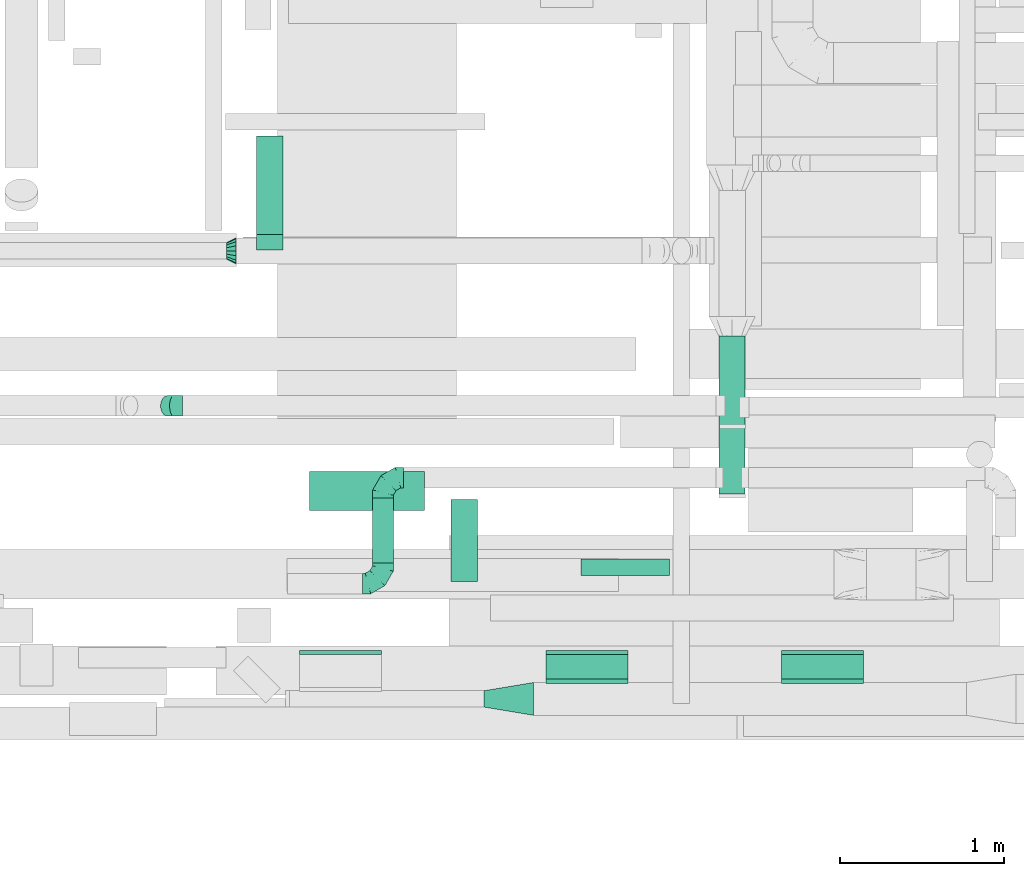
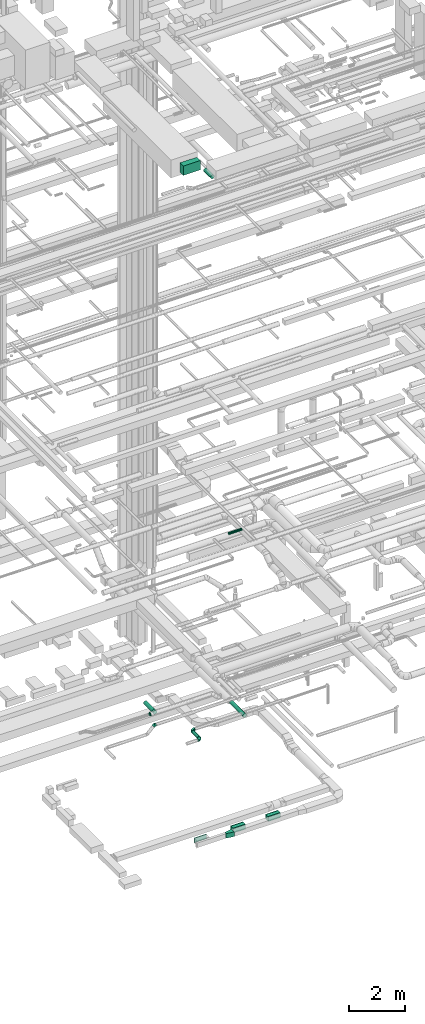
# One storey, part 116 of 337: 11 flow fittings, 8 flow segments.
"""IFC2X3 building model written with IfcOpenShell, lengths in millimetres."""

from ifc_helpers import new_model, entity, si_unit, converted_unit, derived_unit, direction, frame, origin, origin_2d_with_axis, place, context, subcontext, project, spatial, polyline, rectangle, circle, outline, extrude, faceted_brep, source, transform, mapped, material, type_object, type_shapes, element, save


model = new_model("IFC2X3")

# Units and contexts
model_context = context("Model", 3, precision=0.01, world=origin(), true_north=direction((6.12303176911189e-17, 1.0)))
body_context = subcontext(model_context, "Body", "Model", "MODEL_VIEW")
ifc_project = project(units=[si_unit("LENGTHUNIT", "METRE", prefix="MILLI"), si_unit("AREAUNIT", "SQUARE_METRE"), si_unit("VOLUMEUNIT", "CUBIC_METRE"), converted_unit("PLANEANGLEUNIT", "DEGREE", entity("IfcRatioMeasure", 0.0174532925199433), si_unit("PLANEANGLEUNIT", "RADIAN"), dimensions=[0, 0, 0, 0, 0, 0, 0]), si_unit("MASSUNIT", "GRAM", prefix="KILO"), derived_unit("MASSDENSITYUNIT", [(si_unit("MASSUNIT", "GRAM", prefix="KILO"), 1), (si_unit("LENGTHUNIT", "METRE"), -3)]), derived_unit("MOMENTOFINERTIAUNIT", [(si_unit("LENGTHUNIT", "METRE"), 4)]), si_unit("TIMEUNIT", "SECOND"), si_unit("FREQUENCYUNIT", "HERTZ"), si_unit("THERMODYNAMICTEMPERATUREUNIT", "DEGREE_CELSIUS"), derived_unit("THERMALTRANSMITTANCEUNIT", [(si_unit("MASSUNIT", "GRAM", prefix="KILO"), 1), (si_unit("THERMODYNAMICTEMPERATUREUNIT", "KELVIN"), -1), (si_unit("TIMEUNIT", "SECOND"), -3)]), derived_unit("VOLUMETRICFLOWRATEUNIT", [(si_unit("LENGTHUNIT", "METRE"), 3), (si_unit("TIMEUNIT", "SECOND"), -1)]), derived_unit("MASSFLOWRATEUNIT", [(si_unit("MASSUNIT", "GRAM", prefix="KILO"), 1), (si_unit("TIMEUNIT", "SECOND"), -1)]), derived_unit("ROTATIONALFREQUENCYUNIT", [(si_unit("TIMEUNIT", "SECOND"), -1)]), si_unit("ELECTRICCURRENTUNIT", "AMPERE"), si_unit("ELECTRICVOLTAGEUNIT", "VOLT"), si_unit("POWERUNIT", "WATT"), si_unit("FORCEUNIT", "NEWTON", prefix="KILO"), si_unit("ILLUMINANCEUNIT", "LUX"), si_unit("LUMINOUSFLUXUNIT", "LUMEN"), si_unit("LUMINOUSINTENSITYUNIT", "CANDELA"), derived_unit("USERDEFINED", [(si_unit("MASSUNIT", "GRAM", prefix="KILO"), -1), (si_unit("LENGTHUNIT", "METRE"), -2), (si_unit("TIMEUNIT", "SECOND"), 3), (si_unit("LUMINOUSFLUXUNIT", "LUMEN"), 1)]), derived_unit("LINEARVELOCITYUNIT", [(si_unit("LENGTHUNIT", "METRE"), 1), (si_unit("TIMEUNIT", "SECOND"), -1)]), si_unit("PRESSUREUNIT", "PASCAL"), derived_unit("USERDEFINED", [(si_unit("LENGTHUNIT", "METRE"), -2), (si_unit("MASSUNIT", "GRAM", prefix="KILO"), 1), (si_unit("TIMEUNIT", "SECOND"), -2)]), derived_unit("LINEARFORCEUNIT", [(si_unit("MASSUNIT", "GRAM", prefix="KILO"), 1), (si_unit("LENGTHUNIT", "METRE"), 1), (si_unit("TIMEUNIT", "SECOND"), -2), (si_unit("LENGTHUNIT", "METRE"), -1)]), derived_unit("PLANARFORCEUNIT", [(si_unit("MASSUNIT", "GRAM", prefix="KILO"), 1), (si_unit("LENGTHUNIT", "METRE"), 1), (si_unit("TIMEUNIT", "SECOND"), -2), (si_unit("LENGTHUNIT", "METRE"), -2)])], contexts=[model_context])

# Site, building, storey
site_placement = place(None, origin())
site = spatial("IfcSite", under=ifc_project, at=site_placement, CompositionType="ELEMENT")
building_placement = place(site_placement, origin())
building = spatial("IfcBuilding", under=site, at=building_placement, CompositionType="ELEMENT")
storey_placement = place(building_placement, origin())
storey = spatial("IfcBuildingStorey", under=building, at=storey_placement, CompositionType="ELEMENT", Elevation=0.0)

# Flow segments
duct_segment_type_1 = type_object("IfcDuctSegmentType", PredefinedType="NOTDEFINED")
flow_segment_1_placement = place(storey_placement, frame((28490.66, 768.22, -1000.0)))
element("IfcFlowSegment", 1, at=flow_segment_1_placement, inside=storey, type_object=duct_segment_type_1, context=body_context, shape_type="SweptSolid", body=[
    extrude(rectangle(XDim=149.999999999893, YDim=499.999999999999, at=origin_2d_with_axis()), frame((250.0, 75.0, 0.0), z_axis=(0.0, 0.0, 1.0), x_axis=(0.0, 1.0, 0.0)), (0.0, 0.0, 1.0), 200.0),
])
flow_segment_2_placement = place(storey_placement, frame((29923.65, 768.22, -1000.0)))
element("IfcFlowSegment", 2, at=flow_segment_2_placement, inside=storey, type_object=duct_segment_type_1, context=body_context, shape_type="SweptSolid", body=[
    extrude(rectangle(XDim=149.999999999862, YDim=499.999999999999, at=origin_2d_with_axis()), frame((250.0, 75.0, 0.0), z_axis=(0.0, 0.0, 1.0), x_axis=(0.0, 1.0, 0.0)), (0.0, 0.0, 1.0), 200.0),
])
flow_segment_3_placement = place(storey_placement, frame((27050.62, 1794.06, 27350.0)))
element("IfcFlowSegment", 3, at=flow_segment_3_placement, inside=storey, type_object=duct_segment_type_1, context=body_context, shape_type="SweptSolid", body=[
    extrude(rectangle(XDim=239.999999999895, YDim=700.000000000001, at=origin_2d_with_axis()), frame((350.0, 120.0, 0.0), z_axis=(0.0, 0.0, 1.0), x_axis=(0.0, 1.0, 0.0)), (0.0, 0.0, 1.0), 399.999999999996),
])
duct_segment_type_2 = type_object("IfcDuctSegmentType", PredefinedType="NOTDEFINED")
flow_segment_4_placement = place(storey_placement, frame((28703.43, 1398.72, 11418.4)))
element("IfcFlowSegment", 4, at=flow_segment_4_placement, inside=storey, type_object=duct_segment_type_2, context=body_context, shape_type="SweptSolid", body=[
    extrude(circle(Radius=50.0, at=origin_2d_with_axis()), frame((0.0, 51.6, 51.6), z_axis=(1.0, 0.0, 0.0), x_axis=(0.0, 1.0, 0.0)), (0.0, 0.0, 1.0), 540.000000000146),
])
flow_segment_5_placement = place(storey_placement, frame((29542.65, 1896.01, 2918.4)))
element("IfcFlowSegment", 5, at=flow_segment_5_placement, inside=storey, type_object=duct_segment_type_2, context=body_context, shape_type="SweptSolid", body=[
    extrude(circle(Radius=80.0, at=origin_2d_with_axis()), frame((81.6, 0.0, 81.6), z_axis=(0.0, 1.0, 0.0), x_axis=(-1.0, 0.0, 0.0)), (0.0, 0.0, 1.0), 960.0),
])
flow_segment_6_placement = place(storey_placement, frame((26728.31, 3475.7, 3138.4)))
element("IfcFlowSegment", 6, at=flow_segment_6_placement, inside=storey, type_object=duct_segment_type_2, context=body_context, shape_type="SweptSolid", body=[
    extrude(circle(Radius=80.0, at=origin_2d_with_axis()), frame((81.6, 0.0, 81.6), z_axis=(0.0, 1.0, 0.0), x_axis=(1.0, 0.0, 0.0)), (0.0, 0.0, 1.0), 599.999999999912),
])
flow_segment_7_placement = place(storey_placement, frame((27912.15, 1361.51, 27138.4)))
element("IfcFlowSegment", 7, at=flow_segment_7_placement, inside=storey, type_object=duct_segment_type_2, context=body_context, shape_type="SweptSolid", body=[
    extrude(circle(Radius=80.0, at=origin_2d_with_axis()), frame((81.6, 0.0, 81.6), z_axis=(0.0, 1.0, 0.0), x_axis=(1.0, 0.0, 0.0)), (0.0, 0.0, 1.0), 500.000000000006),
])
flow_segment_8_placement = place(storey_placement, frame((27434.93, 1475.7, 2985.9)))
element("IfcFlowSegment", 8, at=flow_segment_8_placement, inside=storey, type_object=duct_segment_type_2, context=body_context, shape_type="SweptSolid", body=[
    extrude(circle(Radius=62.5, at=origin_2d_with_axis()), frame((64.1, 0.0, 64.1), z_axis=(0.0, 1.0, 0.0), x_axis=(-1.0, 0.0, 0.0)), (0.0, 0.0, 1.0), 395.000000000017),
])

# Flow fittings
ifc_material = material()
duct_fitting_type_1 = type_object("IfcDuctFittingType", PredefinedType="NOTDEFINED", material=ifc_material)
shared_shape_1 = source(origin(), body_context, "Body", "SweptSolid", [
    extrude(outline(polyline([(-164.4, -73.98), (139.74, -73.98), (156.18, 24.66), (-131.52, 123.3), (-164.4, -73.98)])), frame((150.0, 0.0, -100.0), z_axis=(0.0, 0.0, 1.0), x_axis=(0.986393923832144, 0.164398987305356, 0.0)), (0.0, 0.0, 1.0), 200.0),
])
type_shapes(duct_fitting_type_1, [shared_shape_1])
flow_fitting_1_placement = place(storey_placement, frame((28414.6, 648.22, -900.0), z_axis=(0.0, 0.0, 1.0), x_axis=(-1.0, 0.0, 0.0)))
element("IfcFlowFitting", 9, at=flow_fitting_1_placement, inside=storey, type_object=duct_fitting_type_1, material=ifc_material, context=body_context, shape_type="MappedRepresentation", body=[
    mapped(shared_shape_1, transform((0.0, 0.0, 0.0), scale=1.0)),
])
duct_fitting_type_2 = type_object("IfcDuctFittingType", PredefinedType="NOTDEFINED", material=ifc_material)
shared_shape_2 = source(origin(), body_context, "Body", "SweptSolid", [
    extrude(rectangle(XDim=500.0, YDim=26.0960000002426, at=origin_2d_with_axis()), frame((6.95, 0.0, -100.0), z_axis=(0.0, 0.0, 1.0), x_axis=(0.0, -1.0, 0.0)), (0.0, 0.0, 1.0), 200.0),
])
type_shapes(duct_fitting_type_2, [shared_shape_2])
for number, where, z_axis, x_axis in (
    (10, (28740.66, 748.22, -900.0), (0.0, 0.0, -1.0), (0.0, 1.0, 0.0)),
    (11, (30173.65, 748.22, -900.0), (0.0, 0.0, -1.0), (0.0, 1.0, 0.0)),
):
    element("IfcFlowFitting", number, at=place(storey_placement, frame(where, z_axis=z_axis, x_axis=x_axis)), inside=storey, type_object=duct_fitting_type_2, material=ifc_material, context=body_context, shape_type="MappedRepresentation", body=[
        mapped(shared_shape_2, transform((0.0, 0.0, 0.0), scale=1.0)),
    ])
duct_fitting_type_3 = type_object("IfcDuctFittingType", PredefinedType="NOTDEFINED", material=ifc_material)
shared_shape_3 = source(origin(), body_context, "Body", "SweptSolid", [
    extrude(rectangle(XDim=24.9999999999999, YDim=500.0, at=origin_2d_with_axis()), frame((12.5, 0.0, -100.0)), (0.0, 0.0, 1.0), 200.0),
])
type_shapes(duct_fitting_type_3, [shared_shape_3])
for number, where, z_axis, x_axis in (
    (12, (30173.65, 918.22, -900.0), (0.0, 0.0, 1.0), (0.0, 1.0, 0.0)),
    (13, (28740.66, 918.22, -900.0), (0.0, 0.0, 1.0), (0.0, 1.0, 0.0)),
    (14, (27240.21, 918.22, -900.0), (0.0, 0.0, 1.0), (0.0, 1.0, 0.0)),
):
    element("IfcFlowFitting", number, at=place(storey_placement, frame(where, z_axis=z_axis, x_axis=x_axis)), inside=storey, type_object=duct_fitting_type_3, material=ifc_material, context=body_context, shape_type="MappedRepresentation", body=[
        mapped(shared_shape_3, transform((0.0, 0.0, 0.0), scale=1.0)),
    ])
duct_fitting_type_4 = type_object("IfcDuctFittingType", PredefinedType="NOTDEFINED", material=ifc_material)
shared_shape_4 = source(origin(), body_context, "Body", "Brep", [
    faceted_brep([(-125.0, 0.0, -62.5), (-125.0, -16.18, -60.37), (-125.0, -31.25, -54.13), (-125.0, -44.19, -44.19), (-125.0, -54.13, -31.25), (-125.0, -60.37, -16.18), (-125.0, -62.5, 0.0), (-125.0, -60.37, 16.18), (-125.0, -54.13, 31.25), (-125.0, -44.19, 44.19), (-125.0, -31.25, 54.13), (-125.0, -16.18, 60.37), (-125.0, 0.0, 62.5), (-125.0, 16.18, 60.37), (-125.0, 31.25, 54.13), (-125.0, 44.19, 44.19), (-125.0, 54.13, 31.25), (-125.0, 60.37, 16.18), (-125.0, 62.5, 0.0), (-125.0, 60.37, -16.18), (-125.0, 54.13, -31.25), (-125.0, 44.19, -44.19), (-125.0, 31.25, -54.13), (-125.0, 16.18, -60.37), (-95.84, 16.18, 60.37), (-99.88, 31.25, 54.13), (-91.51, 0.0, 62.5), (-103.35, 44.19, 44.19), (-107.68, 60.37, 16.18), (-108.25, 62.5, 0.0), (-106.01, 54.13, 31.25), (-106.01, 54.13, -31.25), (-103.35, 44.19, -44.19), (-107.68, 60.37, -16.18), (-95.84, 16.18, -60.37), (-91.51, 0.0, -62.5), (-99.88, 31.25, -54.13), (-87.17, -16.18, -60.37), (-83.13, -31.25, -54.13), (-79.66, -44.19, -44.19), (-77.0, -54.13, -31.25), (-75.33, -60.37, -16.18), (-74.76, -62.5, 0.0), (-75.33, -60.37, 16.18), (-77.0, -54.13, 31.25), (-79.66, -44.19, 44.19), (-83.13, -31.25, 54.13), (-87.17, -16.18, 60.37), (-45.34, 45.34, 60.37), (-56.37, 56.37, 54.13), (-33.49, 33.49, 62.5), (-65.85, 65.85, 44.19), (-73.12, 73.12, 31.25), (-77.69, 77.69, 16.18), (-79.25, 79.25, 0.0), (-77.69, 77.69, -16.18), (-73.12, 73.12, -31.25), (-65.85, 65.85, -44.19), (-45.34, 45.34, -60.37), (-33.49, 33.49, -62.5), (-56.37, 56.37, -54.13), (-21.65, 21.65, -60.37), (-10.62, 10.62, -54.13), (-1.14, 1.14, -44.19), (6.13, -6.13, -31.25), (10.7, -10.7, -16.18), (12.26, -12.26, 0.0), (10.7, -10.7, 16.18), (6.13, -6.13, 31.25), (-1.14, 1.14, 44.19), (-10.62, 10.62, 54.13), (-21.65, 21.65, 60.37), (-16.18, 95.84, 60.37), (-31.25, 99.88, 54.13), (0.0, 91.51, 62.5), (-44.19, 103.35, 44.19), (-54.13, 106.01, 31.25), (-60.37, 107.68, 16.18), (-62.5, 108.25, 0.0), (-60.37, 107.68, -16.18), (-54.13, 106.01, -31.25), (-44.19, 103.35, -44.19), (-16.18, 95.84, -60.37), (0.0, 91.51, -62.5), (-31.25, 99.88, -54.13), (16.18, 87.17, -60.37), (31.25, 83.13, -54.13), (44.19, 79.66, -44.19), (54.13, 77.0, -31.25), (60.37, 75.33, -16.18), (62.5, 74.76, 0.0), (60.37, 75.33, 16.18), (54.13, 77.0, 31.25), (44.19, 79.66, 44.19), (31.25, 83.13, 54.13), (16.18, 87.17, 60.37), (-16.18, 125.0, -60.37), (-31.25, 125.0, -54.13), (-44.19, 125.0, -44.19), (-54.13, 125.0, -31.25), (-60.37, 125.0, -16.18), (-62.5, 125.0, 0.0), (-60.37, 125.0, 16.18), (-54.13, 125.0, 31.25), (-44.19, 125.0, 44.19), (-31.25, 125.0, 54.13), (-16.18, 125.0, 60.37), (0.0, 125.0, 62.5), (16.18, 125.0, 60.37), (31.25, 125.0, 54.13), (44.19, 125.0, 44.19), (54.13, 125.0, 31.25), (60.37, 125.0, 16.18), (62.5, 125.0, 0.0), (60.37, 125.0, -16.18), (54.13, 125.0, -31.25), (44.19, 125.0, -44.19), (31.25, 125.0, -54.13), (16.18, 125.0, -60.37), (0.0, 125.0, -62.5)], [[[0, 1, 2, 3, 4, 5, 6, 7, 8, 9, 10, 11, 12, 13, 14, 15, 16, 17, 18, 19, 20, 21, 22, 23]], [[24, 25, 14, 13]], [[26, 24, 13, 12]], [[14, 25, 27, 15]], [[28, 29, 18, 17]], [[30, 28, 17, 16]], [[15, 27, 30, 16]], [[20, 31, 32, 21]], [[33, 31, 20, 19]], [[18, 29, 33, 19]], [[34, 35, 0, 23]], [[36, 34, 23, 22]], [[21, 32, 36, 22]], [[1, 0, 35, 37]], [[2, 1, 37, 38]], [[38, 39, 3, 2]], [[5, 4, 40, 41]], [[6, 5, 41, 42]], [[39, 40, 4, 3]], [[6, 42, 43, 7]], [[7, 43, 44, 8]], [[45, 9, 8, 44]], [[9, 45, 46, 10]], [[10, 46, 47, 11]], [[26, 12, 11, 47]], [[48, 49, 25, 24]], [[50, 48, 24, 26]], [[27, 25, 49, 51]], [[52, 53, 28, 30]], [[51, 52, 30, 27]], [[29, 28, 53, 54]], [[55, 56, 31, 33]], [[54, 55, 33, 29]], [[57, 32, 31, 56]], [[58, 59, 35, 34]], [[60, 58, 34, 36]], [[57, 60, 36, 32]], [[37, 35, 59, 61]], [[38, 37, 61, 62]], [[39, 38, 62, 63]], [[41, 40, 64, 65]], [[42, 41, 65, 66]], [[63, 64, 40, 39]], [[43, 42, 66, 67]], [[44, 43, 67, 68]], [[68, 69, 45, 44]], [[46, 45, 69, 70]], [[47, 46, 70, 71]], [[26, 47, 71, 50]], [[72, 73, 49, 48]], [[74, 72, 48, 50]], [[51, 49, 73, 75]], [[76, 77, 53, 52]], [[75, 76, 52, 51]], [[54, 53, 77, 78]], [[79, 80, 56, 55]], [[78, 79, 55, 54]], [[81, 57, 56, 80]], [[82, 83, 59, 58]], [[84, 82, 58, 60]], [[81, 84, 60, 57]], [[61, 59, 83, 85]], [[62, 61, 85, 86]], [[63, 62, 86, 87]], [[65, 64, 88, 89]], [[66, 65, 89, 90]], [[87, 88, 64, 63]], [[67, 66, 90, 91]], [[68, 67, 91, 92]], [[92, 93, 69, 68]], [[70, 69, 93, 94]], [[71, 70, 94, 95]], [[50, 71, 95, 74]], [[96, 97, 98, 99, 100, 101, 102, 103, 104, 105, 106, 107, 108, 109, 110, 111, 112, 113, 114, 115, 116, 117, 118, 119]], [[72, 74, 107, 106]], [[73, 72, 106, 105]], [[75, 73, 105, 104]], [[77, 76, 103, 102]], [[78, 77, 102, 101]], [[75, 104, 103, 76]], [[78, 101, 100, 79]], [[79, 100, 99, 80]], [[80, 99, 98, 81]], [[96, 119, 83, 82]], [[97, 96, 82, 84]], [[84, 81, 98, 97]], [[83, 119, 118, 85]], [[85, 118, 117, 86]], [[116, 87, 86, 117]], [[88, 115, 114, 89]], [[89, 114, 113, 90]], [[115, 88, 87, 116]], [[91, 90, 113, 112]], [[92, 91, 112, 111]], [[111, 110, 93, 92]], [[95, 94, 109, 108]], [[74, 95, 108, 107]], [[110, 109, 94, 93]]]),
])
type_shapes(duct_fitting_type_4, [shared_shape_4])
flow_fitting_2_placement = place(storey_placement, frame((27499.02, 1995.7, 3050.0), z_axis=(0.0, 0.0, 1.0), x_axis=(-1.0, 0.0, 0.0)))
element("IfcFlowFitting", 15, at=flow_fitting_2_placement, inside=storey, type_object=duct_fitting_type_4, material=ifc_material, context=body_context, shape_type="MappedRepresentation", body=[
    mapped(shared_shape_4, transform((0.0, 0.0, 0.0), scale=1.0)),
])
flow_fitting_3_placement = place(storey_placement, frame((27499.02, 1350.7, 3050.0)))
element("IfcFlowFitting", 16, at=flow_fitting_3_placement, inside=storey, type_object=duct_fitting_type_4, material=ifc_material, context=body_context, shape_type="MappedRepresentation", body=[
    mapped(shared_shape_4, transform((0.0, 0.0, 0.0), scale=1.0)),
])
duct_fitting_type_5 = type_object("IfcDuctFittingType", PredefinedType="NOTDEFINED", material=ifc_material)
shared_shape_5 = source(origin(), body_context, "Body", "Brep", [
    faceted_brep([(-51.78, 0.0, -62.5), (-51.78, -16.18, -60.37), (-51.78, -31.25, -54.13), (-51.78, -44.19, -44.19), (-51.78, -54.13, -31.25), (-51.78, -60.37, -16.18), (-51.78, -62.5, 0.0), (-51.78, -60.37, 16.18), (-51.78, -54.13, 31.25), (-51.78, -44.19, 44.19), (-51.78, -31.25, 54.13), (-51.78, -16.18, 60.37), (-51.78, 0.0, 62.5), (-51.78, 16.18, 60.37), (-51.78, 31.25, 54.13), (-51.78, 44.19, 44.19), (-51.78, 54.13, 31.25), (-51.78, 60.37, 16.18), (-51.78, 62.5, 0.0), (-51.78, 60.37, -16.18), (-51.78, 54.13, -31.25), (-51.78, 44.19, -44.19), (-51.78, 31.25, -54.13), (-51.78, 16.18, -60.37), (-6.7, 16.18, 60.37), (-12.94, 31.25, 54.13), (0.0, 0.0, 62.5), (-18.31, 44.19, 44.19), (-22.42, 54.13, 31.25), (-25.01, 60.37, 16.18), (-25.89, 62.5, 0.0), (-25.01, 60.37, -16.18), (-22.42, 54.13, -31.25), (-18.31, 44.19, -44.19), (-6.7, 16.18, -60.37), (0.0, 0.0, -62.5), (-12.94, 31.25, -54.13), (6.7, -16.18, -60.37), (12.94, -31.25, -54.13), (18.31, -44.19, -44.19), (22.42, -54.13, -31.25), (25.01, -60.37, -16.18), (25.89, -62.5, 0.0), (25.01, -60.37, 16.18), (22.42, -54.13, 31.25), (18.31, -44.19, 44.19), (12.94, -31.25, 54.13), (6.7, -16.18, 60.37), (25.17, 48.05, 60.37), (14.51, 58.71, 54.13), (36.61, 36.61, 62.5), (5.36, 67.86, 44.19), (-1.66, 74.88, 31.25), (-6.08, 79.3, 16.18), (-7.58, 80.81, 0.0), (-6.08, 79.3, -16.18), (-1.66, 74.88, -31.25), (5.36, 67.86, -44.19), (14.51, 58.71, -54.13), (25.17, 48.05, -60.37), (36.61, 36.61, -62.5), (48.05, 25.17, -60.37), (58.71, 14.51, -54.13), (67.86, 5.36, -44.19), (74.88, -1.66, -31.25), (79.3, -6.08, -16.18), (80.81, -7.58, 0.0), (79.3, -6.08, 16.18), (74.88, -1.66, 31.25), (67.86, 5.36, 44.19), (58.71, 14.51, 54.13), (48.05, 25.17, 60.37)], [[[0, 1, 2, 3, 4, 5, 6, 7, 8, 9, 10, 11, 12, 13, 14, 15, 16, 17, 18, 19, 20, 21, 22, 23]], [[24, 25, 14, 13]], [[26, 24, 13, 12]], [[27, 15, 14, 25]], [[28, 29, 17, 16]], [[28, 16, 15, 27]], [[30, 18, 17, 29]], [[31, 32, 20, 19]], [[30, 31, 19, 18]], [[21, 20, 32, 33]], [[34, 35, 0, 23]], [[36, 34, 23, 22]], [[33, 36, 22, 21]], [[1, 0, 35, 37]], [[2, 1, 37, 38]], [[38, 39, 3, 2]], [[5, 4, 40, 41]], [[6, 5, 41, 42]], [[39, 40, 4, 3]], [[6, 42, 43, 7]], [[7, 43, 44, 8]], [[8, 44, 45, 9]], [[9, 45, 46, 10]], [[10, 46, 47, 11]], [[26, 12, 11, 47]], [[48, 49, 25, 24]], [[50, 48, 24, 26]], [[27, 25, 49, 51]], [[29, 28, 52, 53]], [[30, 29, 53, 54]], [[51, 52, 28, 27]], [[30, 54, 55, 31]], [[31, 55, 56, 32]], [[57, 33, 32, 56]], [[36, 58, 59, 34]], [[34, 59, 60, 35]], [[58, 36, 33, 57]], [[35, 60, 61, 37]], [[37, 61, 62, 38]], [[63, 39, 38, 62]], [[40, 64, 65, 41]], [[41, 65, 66, 42]], [[64, 40, 39, 63]], [[43, 42, 66, 67]], [[44, 43, 67, 68]], [[68, 69, 45, 44]], [[47, 46, 70, 71]], [[26, 47, 71, 50]], [[69, 70, 46, 45]], [[59, 58, 57, 56, 55, 54, 53, 52, 51, 49, 48, 50, 71, 70, 69, 68, 67, 66, 65, 64, 63, 62, 61, 60]]]),
])
type_shapes(duct_fitting_type_5, [shared_shape_5])
flow_fitting_4_placement = place(storey_placement, frame((26225.76, 2432.13, 3450.0), z_axis=(0.0, -1.0, 0.0), x_axis=(-1.0, 0.0, 0.0)))
element("IfcFlowFitting", 17, at=flow_fitting_4_placement, inside=storey, type_object=duct_fitting_type_5, material=ifc_material, context=body_context, shape_type="MappedRepresentation", body=[
    mapped(shared_shape_5, transform((0.0, 0.0, 0.0), scale=1.0)),
])
duct_fitting_type_6 = type_object("IfcDuctFittingType", PredefinedType="NOTDEFINED", material=ifc_material)
shared_shape_6 = source(origin(), body_context, "Body", "Brep", [
    faceted_brep([(60.0, 0.0, -80.0), (60.0, 14.27, -77.16), (60.0, 30.61, -73.91), (60.0, 43.59, -65.24), (60.0, 56.57, -56.57), (60.0, 65.24, -43.59), (60.0, 73.91, -30.61), (60.0, 77.16, -14.27), (60.0, 80.0, 0.0), (60.0, 77.16, 14.27), (60.0, 73.91, 30.61), (60.0, 65.24, 43.59), (60.0, 56.57, 56.57), (60.0, 43.59, 65.24), (60.0, 30.61, 73.91), (60.0, 14.27, 77.16), (60.0, 0.0, 80.0), (60.0, -14.27, 77.16), (60.0, -30.61, 73.91), (60.0, -43.59, 65.24), (60.0, -56.57, 56.57), (60.0, -65.24, 43.59), (60.0, -73.91, 30.61), (60.0, -77.16, 14.27), (60.0, -80.0, 0.0), (60.0, -77.16, -14.27), (60.0, -73.91, -30.61), (60.0, -65.24, -43.59), (60.0, -56.57, -56.57), (60.0, -43.59, -65.24), (60.0, -30.61, -73.91), (60.0, -14.27, -77.16), (0.0, -19.13, -46.19), (0.0, -27.24, -40.77), (0.0, -35.36, -35.36), (0.0, -40.77, -27.24), (0.0, -46.19, -19.13), (0.0, -48.1, -9.57), (0.0, -50.0, 0.0), (0.0, -48.1, 9.57), (0.0, -46.19, 19.13), (0.0, -40.77, 27.24), (0.0, -35.36, 35.36), (0.0, -27.24, 40.77), (0.0, -19.13, 46.19), (0.0, -9.57, 48.1), (0.0, 0.0, 50.0), (0.0, 9.57, 48.1), (0.0, 19.13, 46.19), (0.0, 27.24, 40.77), (0.0, 35.36, 35.36), (0.0, 40.77, 27.24), (0.0, 46.19, 19.13), (0.0, 48.1, 9.57), (0.0, 50.0, 0.0), (0.0, 48.1, -9.57), (0.0, 46.19, -19.13), (0.0, 40.77, -27.24), (0.0, 35.36, -35.36), (0.0, 27.24, -40.77), (0.0, 19.13, -46.19), (0.0, 9.57, -48.1), (0.0, 0.0, -50.0), (0.0, -9.57, -48.1)], [[[0, 1, 2, 3, 4, 5, 6, 7, 8, 9, 10, 11, 12, 13, 14, 15, 16, 17, 18, 19, 20, 21, 22, 23, 24, 25, 26, 27, 28, 29, 30, 31]], [[32, 33, 34, 35, 36, 37, 38, 39, 40, 41, 42, 43, 44, 45, 46, 47, 48, 49, 50, 51, 52, 53, 54, 55, 56, 57, 58, 59, 60, 61, 62, 63]], [[52, 51, 50, 12, 11, 10]], [[48, 14, 13, 12, 50, 49]], [[10, 9, 8, 54, 53, 52]], [[15, 14, 48, 47, 46, 16]], [[44, 43, 42, 20, 19, 18]], [[40, 22, 21, 20, 42, 41]], [[18, 17, 16, 46, 45, 44]], [[23, 22, 40, 39, 38, 24]], [[36, 35, 34, 28, 27, 26]], [[32, 30, 29, 28, 34, 33]], [[26, 25, 24, 38, 37, 36]], [[31, 30, 32, 63, 62, 0]], [[60, 59, 58, 4, 3, 2]], [[56, 6, 5, 4, 58, 57]], [[2, 1, 0, 62, 61, 60]], [[7, 6, 56, 55, 54, 8]]]),
])
type_shapes(duct_fitting_type_6, [shared_shape_6])
flow_fitting_5_placement = place(storey_placement, frame((26545.46, 3375.7, 3220.0)))
element("IfcFlowFitting", 18, at=flow_fitting_5_placement, inside=storey, type_object=duct_fitting_type_6, material=ifc_material, context=body_context, shape_type="MappedRepresentation", body=[
    mapped(shared_shape_6, transform((0.0, 0.0, 0.0), scale=1.0)),
])
duct_fitting_type_7 = type_object("IfcDuctFittingType", PredefinedType="NOTDEFINED", material=ifc_material)
shared_shape_7 = source(origin(), body_context, "Body", "Brep", [
    faceted_brep([(20.0, 0.0, -80.0), (20.0, 20.71, -77.27), (20.0, 40.0, -69.28), (20.0, 56.57, -56.57), (20.0, 69.28, -40.0), (20.0, 77.27, -20.71), (20.0, 80.0, 0.0), (20.0, 77.27, 20.71), (20.0, 69.28, 40.0), (20.0, 56.57, 56.57), (20.0, 40.0, 69.28), (20.0, 20.71, 77.27), (20.0, 0.0, 80.0), (20.0, -20.71, 77.27), (20.0, -40.0, 69.28), (20.0, -56.57, 56.57), (20.0, -69.28, 40.0), (20.0, -77.27, 20.71), (20.0, -80.0, 0.0), (20.0, -77.27, -20.71), (20.0, -69.28, -40.0), (20.0, -56.57, -56.57), (20.0, -40.0, -69.28), (20.0, -20.71, -77.27), (0.0, 0.0, 80.0), (-73.9, 0.0, 80.0), (-73.9, -20.71, 77.27), (0.0, -20.71, 77.27), (-73.9, -40.0, 69.28), (0.0, -40.0, 69.28), (0.0, -56.57, 56.57), (-73.9, -56.57, 56.57), (0.0, -69.28, 40.0), (-73.9, -69.28, 40.0), (-73.9, -77.27, 20.71), (0.0, -77.27, 20.71), (-73.9, -80.0, 0.0), (0.0, -80.0, 0.0), (-73.9, -77.27, -20.71), (0.0, -77.27, -20.71), (-73.9, -69.28, -40.0), (0.0, -69.28, -40.0), (0.0, -56.57, -56.57), (-73.9, -56.57, -56.57), (0.0, -40.0, -69.28), (-73.9, -40.0, -69.28), (-73.9, -20.71, -77.27), (0.0, -20.71, -77.27), (-73.9, 0.0, -80.0), (0.0, 0.0, -80.0), (-73.9, 20.71, -77.27), (0.0, 20.71, -77.27), (-73.9, 40.0, -69.28), (0.0, 40.0, -69.28), (0.0, 56.57, -56.57), (-73.9, 56.57, -56.57), (0.0, 69.28, -40.0), (-73.9, 69.28, -40.0), (-73.9, 77.27, -20.71), (0.0, 77.27, -20.71), (-73.9, 80.0, 0.0), (0.0, 80.0, 0.0), (-73.9, 77.27, 20.71), (0.0, 77.27, 20.71), (-73.9, 69.28, 40.0), (0.0, 69.28, 40.0), (0.0, 56.57, 56.57), (-73.9, 56.57, 56.57), (0.0, 40.0, 69.28), (-73.9, 40.0, 69.28), (-73.9, 20.71, 77.27), (0.0, 20.71, 77.27)], [[[0, 1, 2, 3, 4, 5, 6, 7, 8, 9, 10, 11, 12, 13, 14, 15, 16, 17, 18, 19, 20, 21, 22, 23]], [[13, 12, 24, 25, 26, 27]], [[14, 13, 27, 26, 28, 29]], [[30, 15, 14, 29, 28, 31]], [[17, 16, 32, 33, 34, 35]], [[18, 17, 35, 34, 36, 37]], [[32, 16, 15, 30, 31, 33]], [[19, 18, 37, 36, 38, 39]], [[20, 19, 39, 38, 40, 41]], [[42, 21, 20, 41, 40, 43]], [[23, 22, 44, 45, 46, 47]], [[0, 23, 47, 46, 48, 49]], [[44, 22, 21, 42, 43, 45]], [[1, 0, 49, 48, 50, 51]], [[2, 1, 51, 50, 52, 53]], [[54, 3, 2, 53, 52, 55]], [[5, 4, 56, 57, 58, 59]], [[6, 5, 59, 58, 60, 61]], [[56, 4, 3, 54, 55, 57]], [[7, 6, 61, 60, 62, 63]], [[8, 7, 63, 62, 64, 65]], [[66, 9, 8, 65, 64, 67]], [[11, 10, 68, 69, 70, 71]], [[12, 11, 71, 70, 25, 24]], [[68, 10, 9, 66, 67, 69]], [[46, 45, 43, 40, 38, 36, 34, 33, 31, 28, 26, 25, 70, 69, 67, 64, 62, 60, 58, 57, 55, 52, 50, 48]]]),
])
type_shapes(duct_fitting_type_7, [shared_shape_7])
flow_fitting_6_placement = place(storey_placement, frame((26809.91, 3455.7, 3220.0), z_axis=(0.0, 0.0, -1.0), x_axis=(0.0, 1.0, 0.0)))
element("IfcFlowFitting", 19, at=flow_fitting_6_placement, inside=storey, type_object=duct_fitting_type_7, material=ifc_material, context=body_context, shape_type="MappedRepresentation", body=[
    mapped(shared_shape_7, transform((0.0, 0.0, 0.0), scale=1.0)),
])

save(model, "model.ifc")
